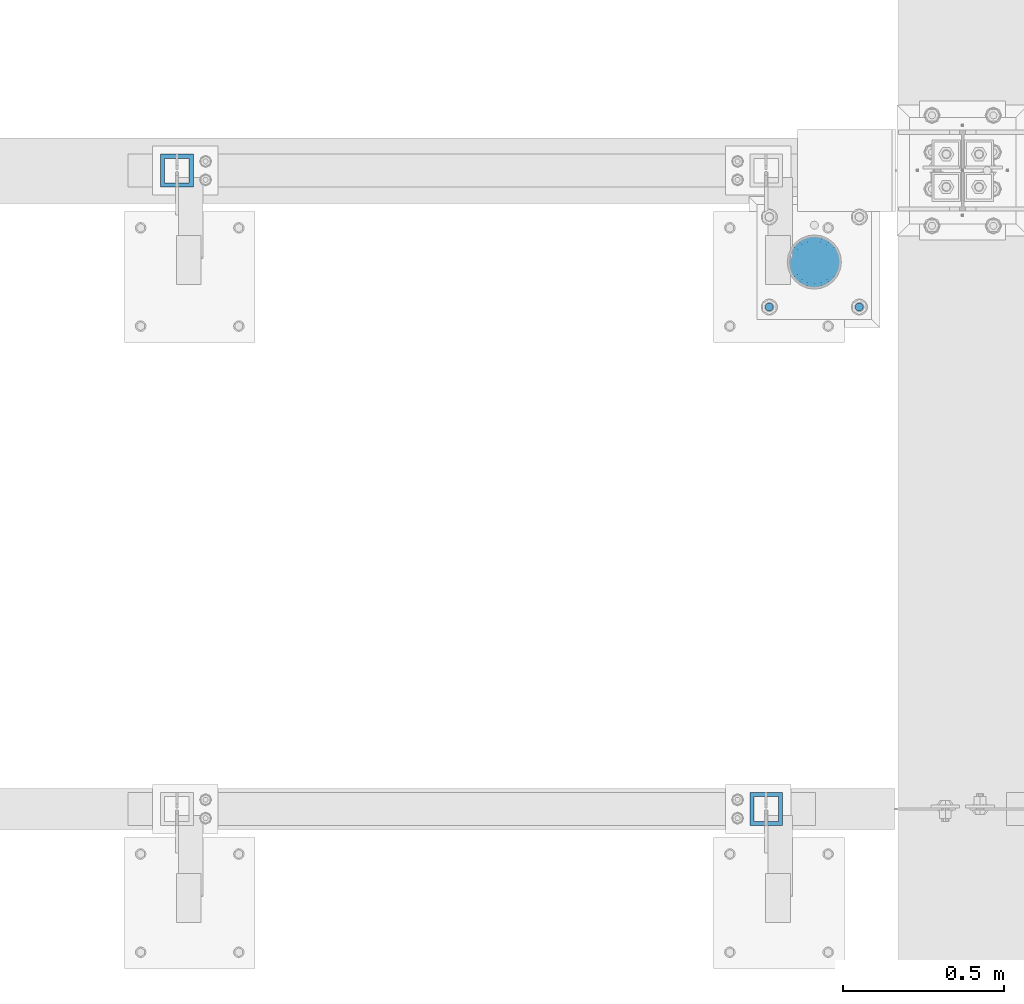
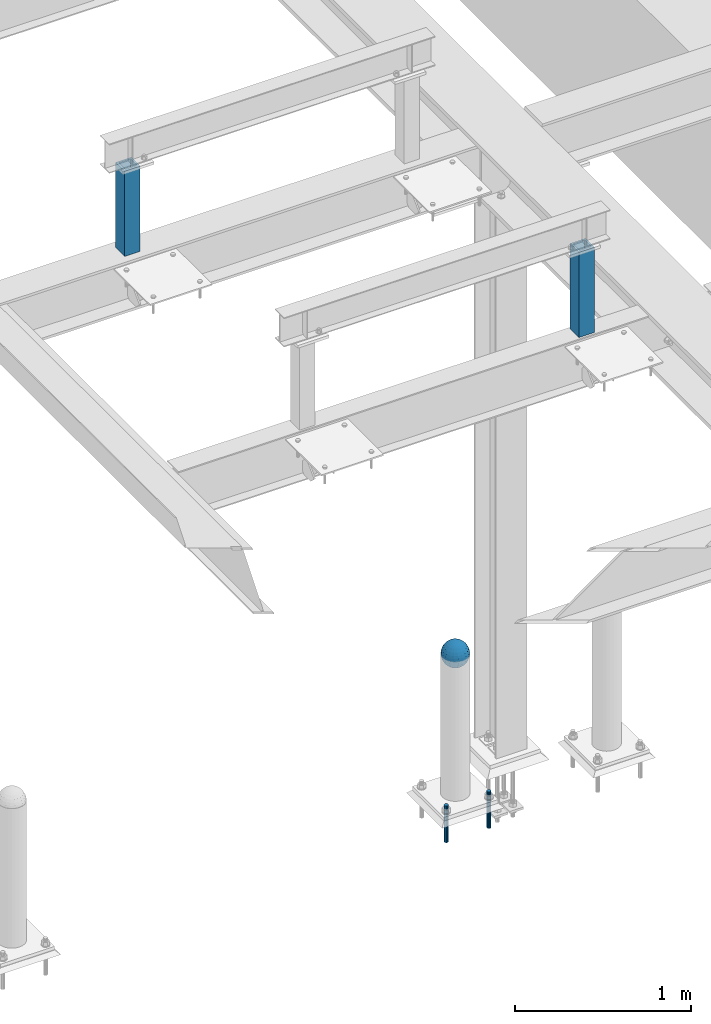
# One storey, part 1443 of 3843: 5 columns, 4 elements without a shape of their own.
"""IFC2X3 building model written with IfcOpenShell, lengths in millimetres."""

from ifc_helpers import new_model, si_unit, frame, origin_with_axes, place, context, subcontext, project, spatial, faceted_brep, material, type_object, element, aggregate, save


model = new_model("IFC2X3")

# Units and contexts
model_context = context("Model", 3, precision=1e-05, world=origin_with_axes())
body_context = subcontext(model_context, "Body", "Model", "MODEL_VIEW")
ifc_project = project(units=[si_unit("LENGTHUNIT", "METRE", prefix="MILLI"), si_unit("AREAUNIT", "SQUARE_METRE"), si_unit("VOLUMEUNIT", "CUBIC_METRE"), si_unit("MASSUNIT", "GRAM", prefix="KILO"), si_unit("TIMEUNIT", "SECOND"), si_unit("PLANEANGLEUNIT", "RADIAN"), si_unit("SOLIDANGLEUNIT", "STERADIAN"), si_unit("THERMODYNAMICTEMPERATUREUNIT", "DEGREE_CELSIUS"), si_unit("LUMINOUSINTENSITYUNIT", "LUMEN")], contexts=[model_context])

# Site, building, storey
site_placement = place(None, origin_with_axes())
site = spatial("IfcSite", under=ifc_project, at=site_placement, CompositionType="ELEMENT")
building_placement = place(site_placement, origin_with_axes())
building = spatial("IfcBuilding", under=site, at=building_placement, Name="Undefined", CompositionType="ELEMENT")
storey_placement = place(building_placement, origin_with_axes())
storey = spatial("IfcBuildingStorey", under=building, at=storey_placement, Name="Undefined", CompositionType="ELEMENT", Elevation=0.0)

# Assembly, column
assembly_1_placement = place(storey_placement, origin_with_axes())
assembly_1 = element("IfcElementAssembly", 1, at=assembly_1_placement, inside=storey, Name="CONC. FILL", AssemblyPlace="NOTDEFINED", PredefinedType="REINFORCEMENT_UNIT")
ifc_material_1 = material(Name="CONCRETE/1500")
column_type_1 = type_object("IfcColumnType", PredefinedType="NOTDEFINED")
column_1_placement = place(assembly_1_placement, frame((36115.6715698242, 14714.9457781578, 31411.8625), z_axis=(-1.0, 0.0, 0.0), x_axis=(0.0, 0.0, 1.0)))
column_1 = element("IfcColumn", 2, at=column_1_placement, type_object=column_type_1, material=ifc_material_1, Name="CONC. FILL", context=body_context, shape_type="Brep", body=[
    faceted_brep([(0.0, 0.0, 2.0), (0.0, -0.619999999995343, 1.89999999999964), (3.36549999999988, -7.1422259999963, 21.9814139999999), (3.36549999999988, 0.0, 23.1139999999996), (0.0, -1.17999999999302, 1.6200000000008), (3.36549999999988, -13.5910319999966, 18.6992260000006), (0.0, -1.61999999999534, 1.18000000000029), (3.36549999999988, -18.699225999997, 13.5910320000003), (0.0, -1.89999999999418, 0.6200000000008), (3.36549999999988, -21.9814139999944, 7.14222599999994), (0.0, -2.0, 0.0), (3.36549999999988, -23.1140000000014, 0.0), (0.0, -1.89999999999418, -0.6200000000008), (3.36549999999988, -21.9814139999944, -7.14222599999994), (0.0, -1.61999999999534, -1.18000000000029), (3.36549999999988, -18.699225999997, -13.5910320000003), (0.0, -1.17999999999302, -1.6200000000008), (3.36549999999988, -13.5910319999966, -18.6992260000006), (0.0, -0.619999999995343, -1.89999999999964), (3.36549999999988, -7.1422259999963, -21.9814139999999), (0.0, 0.0, -2.0), (3.36549999999988, 0.0, -23.1139999999996), (0.0, 0.619999999995343, -1.89999999999964), (3.36549999999988, 7.1422259999963, -21.9814139999999), (0.0, 1.17999999999302, -1.6200000000008), (3.36549999999988, 13.5910319999966, -18.6992260000006), (0.0, 1.61999999999534, -1.18000000000029), (3.36549999999988, 18.699225999997, -13.5910320000003), (0.0, 1.89999999999418, -0.6200000000008), (3.36549999999988, 21.9814139999944, -7.14222599999994), (0.0, 2.0, 0.0), (3.36549999999988, 23.1140000000014, 0.0), (0.0, 1.89999999999418, 0.6200000000008), (3.36549999999988, 21.9814139999944, 7.14222599999994), (0.0, 1.61999999999534, 1.18000000000029), (3.36549999999988, 18.699225999997, 13.5910320000003), (0.0, 1.17999999999302, 1.6200000000008), (3.36549999999988, 13.5910319999966, 18.6992260000006), (0.0, 0.619999999995343, 1.89999999999964), (3.36549999999988, 7.1422259999963, 21.9814139999999), (8.41374999999971, -11.1214661999984, 34.2282018000005), (8.41374999999971, 0.0, 35.9917999999998), (8.41374999999971, -21.1631784000056, 29.1173662000001), (8.41374999999971, -29.1173661999928, 21.1631784000001), (8.41374999999971, -34.2282017999969, 11.1214662000002), (8.41374999999971, -35.9918000000034, 0.0), (8.41374999999971, -34.2282017999969, -11.1214662000002), (8.41374999999971, -29.1173661999928, -21.1631784000001), (8.41374999999971, -21.1631784000056, -29.1173662000001), (8.41374999999971, -11.1214661999984, -34.2282018000005), (8.41374999999971, 0.0, -35.9917999999998), (8.41374999999971, 11.1214661999984, -34.2282018000005), (8.41374999999971, 21.1631784000056, -29.1173662000001), (8.41374999999971, 29.1173661999928, -21.1631784000001), (8.41374999999971, 34.2282017999969, -11.1214662000002), (8.41374999999971, 35.9918000000034, 0.0), (8.41374999999971, 34.2282017999969, 11.1214662000002), (8.41374999999971, 29.1173661999928, 21.1631784000001), (8.41374999999971, 21.1631784000056, 29.1173662000001), (8.41374999999971, 11.1214661999984, 34.2282018000005), (16.8274999999994, -15.3047700000025, 47.1030300000002), (16.8274999999994, 0.0, 49.5300000000007), (16.8274999999994, -29.1236400000053, 40.0697700000001), (16.8274999999994, -40.0697700000019, 29.1236399999998), (16.8274999999994, -47.1030299999984, 15.3047700000006), (16.8274999999994, -49.5299999999988, 0.0), (16.8274999999994, -47.1030299999984, -15.3047700000006), (16.8274999999994, -40.0697700000019, -29.1236399999998), (16.8274999999994, -29.1236400000053, -40.0697700000001), (16.8274999999994, -15.3047700000025, -47.1030300000002), (16.8274999999994, 0.0, -49.5300000000007), (16.8274999999994, 15.3047700000025, -47.1030300000002), (16.8274999999994, 29.1236400000053, -40.0697700000001), (16.8274999999994, 40.0697700000019, -29.1236399999998), (16.8274999999994, 47.1030299999984, -15.3047700000006), (16.8274999999994, 49.5299999999988, 0.0), (16.8274999999994, 47.1030299999984, 15.3047700000006), (16.8274999999994, 40.0697700000019, 29.1236399999998), (16.8274999999994, 29.1236400000053, 40.0697700000001), (16.8274999999994, 15.3047700000025, 47.1030300000002), (33.6549999999988, -20.4063599999936, 62.8040400000009), (33.6549999999988, 0.0, 66.0400000000009), (33.6549999999988, -38.831520000007, 53.4263599999995), (33.6549999999988, -53.4263599999977, 38.8315199999997), (33.6549999999988, -62.8040400000027, 20.4063600000009), (33.6549999999988, -66.0399999999936, 0.0), (33.6549999999988, -62.8040400000027, -20.4063600000009), (33.6549999999988, -53.4263599999977, -38.8315199999997), (33.6549999999988, -38.831520000007, -53.4263599999995), (33.6549999999988, -20.4063599999936, -62.8040400000009), (33.6549999999988, 0.0, -66.0400000000009), (33.6549999999988, 20.4063599999936, -62.8040400000009), (33.6549999999988, 38.831520000007, -53.4263599999995), (33.6549999999988, 53.4263599999977, -38.8315199999997), (33.6549999999988, 62.8040400000027, -20.4063600000009), (33.6549999999988, 66.0399999999936, 0.0), (33.6549999999988, 62.8040400000027, 20.4063600000009), (33.6549999999988, 53.4263599999977, 38.8315199999997), (33.6549999999988, 38.831520000007, 53.4263599999995), (33.6549999999988, 20.4063599999936, 62.8040400000009), (50.4824999999983, -23.3907901500061, 71.9891308499991), (50.4824999999983, 0.0, 75.6983500000006), (50.4824999999983, -44.5106298000028, 61.23996515), (50.4824999999983, -61.2399651500018, 44.5106297999992), (50.4824999999983, -71.9891308499937, 23.3907901500006), (50.4824999999983, -75.698350000006, 0.0), (50.4824999999983, -71.9891308499937, -23.3907901500006), (50.4824999999983, -61.2399651500018, -44.5106297999992), (50.4824999999983, -44.5106298000028, -61.23996515), (50.4824999999983, -23.3907901500061, -71.9891308499991), (50.4824999999983, 0.0, -75.6983500000006), (50.4824999999983, 23.3907901500061, -71.9891308499991), (50.4824999999983, 44.5106298000028, -61.23996515), (50.4824999999983, 61.2399651500018, -44.5106297999992), (50.4824999999983, 71.9891308499937, -23.3907901500006), (50.4824999999983, 75.698350000006, 0.0), (50.4824999999983, 71.9891308499937, 23.3907901500006), (50.4824999999983, 61.2399651500018, 44.5106297999992), (50.4824999999983, 44.5106298000028, 61.23996515), (50.4824999999983, 23.3907901500061, 71.9891308499991), (67.3099999999977, -24.9977910000016, 76.9349490000004), (67.3099999999977, 0.0, 80.8989999999994), (67.3099999999977, -47.5686120000028, 65.4472910000004), (67.3099999999977, -65.447291000004, 47.5686119999991), (67.3099999999977, -76.9349490000022, 24.9977909999998), (67.3099999999977, -80.8990000000049, 0.0), (67.3099999999977, -76.9349490000022, -24.9977909999998), (67.3099999999977, -65.447291000004, -47.5686119999991), (67.3099999999977, -47.5686120000028, -65.4472910000004), (67.3099999999977, -24.9977910000016, -76.9349490000004), (67.3099999999977, 0.0, -80.8989999999994), (67.3099999999977, 24.9977910000016, -76.9349490000004), (67.3099999999977, 47.5686120000028, -65.4472910000004), (67.3099999999977, 65.447291000004, -47.5686119999991), (67.3099999999977, 76.9349490000022, -24.9977909999998), (67.3099999999977, 80.8990000000049, 0.0), (67.3099999999977, 76.9349490000022, 24.9977909999998), (67.3099999999977, 65.447291000004, 47.5686119999991), (67.3099999999977, 47.5686120000028, 65.4472910000004), (67.3099999999977, 24.9977910000016, 76.9349490000004), (84.1374999999935, -25.5079499999993, 78.5050499999998), (84.1374999999935, 0.0, 82.5499999999993), (84.1374999999935, -48.5393999999942, 66.7829500000007), (84.1374999999935, -66.7829499999934, 48.5393999999997), (84.1374999999935, -78.505050000007, 25.5079499999993), (84.1374999999935, -82.5500000000029, 0.0), (84.1374999999935, -78.505050000007, -25.5079499999993), (84.1374999999935, -66.7829499999934, -48.5393999999997), (84.1374999999935, -48.5393999999942, -66.7829500000007), (84.1374999999935, -25.5079499999993, -78.5050499999998), (84.1374999999935, 0.0, -82.5499999999993), (84.1374999999935, 25.5079499999993, -78.5050499999998), (84.1374999999935, 48.5393999999942, -66.7829500000007), (84.1374999999935, 66.7829499999934, -48.5393999999997), (84.1374999999935, 78.505050000007, -25.5079499999993), (84.1374999999935, 82.5500000000029, 0.0), (84.1374999999935, 78.505050000007, 25.5079499999993), (84.1374999999935, 66.7829499999934, 48.5393999999997), (84.1374999999935, 48.5393999999942, 66.7829500000007), (84.1374999999935, 25.5079499999993, 78.5050499999998), (100.964999999993, -24.9977910000016, 76.9349490000004), (100.964999999993, 0.0, 80.8989999999994), (100.964999999993, -47.5686120000028, 65.4472910000004), (100.964999999993, -65.447291000004, 47.5686119999991), (100.964999999993, -76.9349490000022, 24.9977909999998), (100.964999999993, -80.8990000000049, 0.0), (100.964999999993, -76.9349490000022, -24.9977909999998), (100.964999999993, -65.447291000004, -47.5686119999991), (100.964999999993, -47.5686120000028, -65.4472910000004), (100.964999999993, -24.9977910000016, -76.9349490000004), (100.964999999993, 0.0, -80.8989999999994), (100.964999999993, 24.9977910000016, -76.9349490000004), (100.964999999993, 47.5686120000028, -65.4472910000004), (100.964999999993, 65.447291000004, -47.5686119999991), (100.964999999993, 76.9349490000022, -24.9977909999998), (100.964999999993, 80.8990000000049, 0.0), (100.964999999993, 76.9349490000022, 24.9977909999998), (100.964999999993, 65.447291000004, 47.5686119999991), (100.964999999993, 47.5686120000028, 65.4472910000004), (100.964999999993, 24.9977910000016, 76.9349490000004), (117.792499999992, -23.3907901500061, 71.9891308499991), (117.792499999992, 0.0, 75.6983500000006), (117.792499999992, -44.5106298000028, 61.23996515), (117.792499999992, -61.2399651500018, 44.5106297999992), (117.792499999992, -71.9891308499937, 23.3907901500006), (117.792499999992, -75.698350000006, 0.0), (117.792499999992, -71.9891308499937, -23.3907901500006), (117.792499999992, -61.2399651500018, -44.5106297999992), (117.792499999992, -44.5106298000028, -61.23996515), (117.792499999992, -23.3907901500061, -71.9891308499991), (117.792499999992, 0.0, -75.6983500000006), (117.792499999992, 23.3907901500061, -71.9891308499991), (117.792499999992, 44.5106298000028, -61.23996515), (117.792499999992, 61.2399651500018, -44.5106297999992), (117.792499999992, 71.9891308499937, -23.3907901500006), (117.792499999992, 75.698350000006, 0.0), (117.792499999992, 71.9891308499937, 23.3907901500006), (117.792499999992, 61.2399651500018, 44.5106297999992), (117.792499999992, 44.5106298000028, 61.23996515), (117.792499999992, 23.3907901500061, 71.9891308499991), (134.619999999992, -20.4063599999936, 62.8040400000009), (134.619999999992, 0.0, 66.0400000000009), (134.619999999992, -38.831520000007, 53.4263599999995), (134.619999999992, -53.4263599999977, 38.8315199999997), (134.619999999992, -62.8040400000027, 20.4063600000009), (134.619999999992, -66.0399999999936, 0.0), (134.619999999992, -62.8040400000027, -20.4063600000009), (134.619999999992, -53.4263599999977, -38.8315199999997), (134.619999999992, -38.831520000007, -53.4263599999995), (134.619999999992, -20.4063599999936, -62.8040400000009), (134.619999999992, 0.0, -66.0400000000009), (134.619999999992, 20.4063599999936, -62.8040400000009), (134.619999999992, 38.831520000007, -53.4263599999995), (134.619999999992, 53.4263599999977, -38.8315199999997), (134.619999999992, 62.8040400000027, -20.4063600000009), (134.619999999992, 66.0399999999936, 0.0), (134.619999999992, 62.8040400000027, 20.4063600000009), (134.619999999992, 53.4263599999977, 38.8315199999997), (134.619999999992, 38.831520000007, 53.4263599999995), (134.619999999992, 20.4063599999936, 62.8040400000009), (151.447499999991, -15.3047700000025, 47.1030300000002), (151.447499999991, 0.0, 49.5300000000007), (151.447499999991, -29.1236400000053, 40.0697700000001), (151.447499999991, -40.0697700000019, 29.1236399999998), (151.447499999991, -47.1030299999984, 15.3047700000006), (151.447499999991, -49.5299999999988, 0.0), (151.447499999991, -47.1030299999984, -15.3047700000006), (151.447499999991, -40.0697700000019, -29.1236399999998), (151.447499999991, -29.1236400000053, -40.0697700000001), (151.447499999991, -15.3047700000025, -47.1030300000002), (151.447499999991, 0.0, -49.5300000000007), (151.447499999991, 15.3047700000025, -47.1030300000002), (151.447499999991, 29.1236400000053, -40.0697700000001), (151.447499999991, 40.0697700000019, -29.1236399999998), (151.447499999991, 47.1030299999984, -15.3047700000006), (151.447499999991, 49.5299999999988, 0.0), (151.447499999991, 47.1030299999984, 15.3047700000006), (151.447499999991, 40.0697700000019, 29.1236399999998), (151.447499999991, 29.1236400000053, 40.0697700000001), (151.447499999991, 15.3047700000025, 47.1030300000002), (159.861249999991, -11.1214661999984, 34.2282018000005), (159.861249999991, 0.0, 35.9917999999998), (159.861249999991, -21.1631784000056, 29.1173662000001), (159.861249999991, -29.1173661999928, 21.1631784000001), (159.861249999991, -34.2282017999969, 11.1214662000002), (159.861249999991, -35.9918000000034, 0.0), (159.861249999991, -34.2282017999969, -11.1214662000002), (159.861249999991, -29.1173661999928, -21.1631784000001), (159.861249999991, -21.1631784000056, -29.1173662000001), (159.861249999991, -11.1214661999984, -34.2282018000005), (159.861249999991, 0.0, -35.9917999999998), (159.861249999991, 11.1214661999984, -34.2282018000005), (159.861249999991, 21.1631784000056, -29.1173662000001), (159.861249999991, 29.1173661999928, -21.1631784000001), (159.861249999991, 34.2282017999969, -11.1214662000002), (159.861249999991, 35.9918000000034, 0.0), (159.861249999991, 34.2282017999969, 11.1214662000002), (159.861249999991, 29.1173661999928, 21.1631784000001), (159.861249999991, 21.1631784000056, 29.1173662000001), (159.861249999991, 11.1214661999984, 34.2282018000005), (164.909499999991, -7.1422259999963, 21.9814139999999), (164.909499999991, 0.0, 23.1139999999996), (164.909499999991, -13.5910319999966, 18.6992260000006), (164.909499999991, -18.699225999997, 13.5910320000003), (164.909499999991, -21.9814139999944, 7.14222599999994), (164.909499999991, -23.1140000000014, 0.0), (164.909499999991, -21.9814139999944, -7.14222599999994), (164.909499999991, -18.699225999997, -13.5910320000003), (164.909499999991, -13.5910319999966, -18.6992260000006), (164.909499999991, -7.1422259999963, -21.9814139999999), (164.909499999991, 0.0, -23.1139999999996), (164.909499999991, 7.1422259999963, -21.9814139999999), (164.909499999991, 13.5910319999966, -18.6992260000006), (164.909499999991, 18.699225999997, -13.5910320000003), (164.909499999991, 21.9814139999944, -7.14222599999994), (164.909499999991, 23.1140000000014, 0.0), (164.909499999991, 21.9814139999944, 7.14222599999994), (164.909499999991, 18.699225999997, 13.5910320000003), (164.909499999991, 13.5910319999966, 18.6992260000006), (164.909499999991, 7.1422259999963, 21.9814139999999), (168.274999999991, -0.619999999995343, 1.89999999999964), (168.274999999991, 0.0, 2.0), (168.274999999991, -1.17999999999302, 1.6200000000008), (168.274999999991, -1.61999999999534, 1.18000000000029), (168.274999999991, -1.89999999999418, 0.6200000000008), (168.274999999991, -2.0, 0.0), (168.274999999991, -1.89999999999418, -0.6200000000008), (168.274999999991, -1.61999999999534, -1.18000000000029), (168.274999999991, -1.17999999999302, -1.6200000000008), (168.274999999991, -0.619999999995343, -1.89999999999964), (168.274999999991, 0.0, -2.0), (168.274999999991, 0.619999999995343, -1.89999999999964), (168.274999999991, 1.17999999999302, -1.6200000000008), (168.274999999991, 1.61999999999534, -1.18000000000029), (168.274999999991, 1.89999999999418, -0.6200000000008), (168.274999999991, 2.0, 0.0), (168.274999999991, 1.89999999999418, 0.6200000000008), (168.274999999991, 1.61999999999534, 1.18000000000029), (168.274999999991, 1.17999999999302, 1.6200000000008), (168.274999999991, 0.619999999995343, 1.89999999999964)], [[[0, 1, 2, 3]], [[1, 4, 5, 2]], [[4, 6, 7, 5]], [[6, 8, 9, 7]], [[8, 10, 11, 9]], [[10, 12, 13, 11]], [[12, 14, 15, 13]], [[14, 16, 17, 15]], [[16, 18, 19, 17]], [[18, 20, 21, 19]], [[20, 22, 23, 21]], [[22, 24, 25, 23]], [[24, 26, 27, 25]], [[26, 28, 29, 27]], [[28, 30, 31, 29]], [[30, 32, 33, 31]], [[32, 34, 35, 33]], [[34, 36, 37, 35]], [[36, 38, 39, 37]], [[38, 0, 3, 39]], [[38, 36, 34, 32, 30, 28, 26, 24, 22, 20, 18, 16, 14, 12, 10, 8, 6, 4, 1, 0]], [[3, 2, 40, 41]], [[2, 5, 42, 40]], [[5, 7, 43, 42]], [[7, 9, 44, 43]], [[9, 11, 45, 44]], [[11, 13, 46, 45]], [[13, 15, 47, 46]], [[15, 17, 48, 47]], [[17, 19, 49, 48]], [[19, 21, 50, 49]], [[21, 23, 51, 50]], [[23, 25, 52, 51]], [[25, 27, 53, 52]], [[27, 29, 54, 53]], [[29, 31, 55, 54]], [[31, 33, 56, 55]], [[33, 35, 57, 56]], [[35, 37, 58, 57]], [[37, 39, 59, 58]], [[39, 3, 41, 59]], [[41, 40, 60, 61]], [[40, 42, 62, 60]], [[42, 43, 63, 62]], [[43, 44, 64, 63]], [[44, 45, 65, 64]], [[45, 46, 66, 65]], [[46, 47, 67, 66]], [[47, 48, 68, 67]], [[48, 49, 69, 68]], [[49, 50, 70, 69]], [[50, 51, 71, 70]], [[51, 52, 72, 71]], [[52, 53, 73, 72]], [[53, 54, 74, 73]], [[54, 55, 75, 74]], [[55, 56, 76, 75]], [[56, 57, 77, 76]], [[57, 58, 78, 77]], [[58, 59, 79, 78]], [[59, 41, 61, 79]], [[61, 60, 80, 81]], [[60, 62, 82, 80]], [[62, 63, 83, 82]], [[63, 64, 84, 83]], [[64, 65, 85, 84]], [[65, 66, 86, 85]], [[66, 67, 87, 86]], [[67, 68, 88, 87]], [[68, 69, 89, 88]], [[69, 70, 90, 89]], [[70, 71, 91, 90]], [[71, 72, 92, 91]], [[72, 73, 93, 92]], [[73, 74, 94, 93]], [[74, 75, 95, 94]], [[75, 76, 96, 95]], [[76, 77, 97, 96]], [[77, 78, 98, 97]], [[78, 79, 99, 98]], [[79, 61, 81, 99]], [[81, 80, 100, 101]], [[80, 82, 102, 100]], [[82, 83, 103, 102]], [[83, 84, 104, 103]], [[84, 85, 105, 104]], [[85, 86, 106, 105]], [[86, 87, 107, 106]], [[87, 88, 108, 107]], [[88, 89, 109, 108]], [[89, 90, 110, 109]], [[90, 91, 111, 110]], [[91, 92, 112, 111]], [[92, 93, 113, 112]], [[93, 94, 114, 113]], [[94, 95, 115, 114]], [[95, 96, 116, 115]], [[96, 97, 117, 116]], [[97, 98, 118, 117]], [[98, 99, 119, 118]], [[99, 81, 101, 119]], [[101, 100, 120, 121]], [[100, 102, 122, 120]], [[102, 103, 123, 122]], [[103, 104, 124, 123]], [[104, 105, 125, 124]], [[105, 106, 126, 125]], [[106, 107, 127, 126]], [[107, 108, 128, 127]], [[108, 109, 129, 128]], [[109, 110, 130, 129]], [[110, 111, 131, 130]], [[111, 112, 132, 131]], [[112, 113, 133, 132]], [[113, 114, 134, 133]], [[114, 115, 135, 134]], [[115, 116, 136, 135]], [[116, 117, 137, 136]], [[117, 118, 138, 137]], [[118, 119, 139, 138]], [[119, 101, 121, 139]], [[121, 120, 140, 141]], [[120, 122, 142, 140]], [[122, 123, 143, 142]], [[123, 124, 144, 143]], [[124, 125, 145, 144]], [[125, 126, 146, 145]], [[126, 127, 147, 146]], [[127, 128, 148, 147]], [[128, 129, 149, 148]], [[129, 130, 150, 149]], [[130, 131, 151, 150]], [[131, 132, 152, 151]], [[132, 133, 153, 152]], [[133, 134, 154, 153]], [[134, 135, 155, 154]], [[135, 136, 156, 155]], [[136, 137, 157, 156]], [[137, 138, 158, 157]], [[138, 139, 159, 158]], [[139, 121, 141, 159]], [[141, 140, 160, 161]], [[140, 142, 162, 160]], [[142, 143, 163, 162]], [[143, 144, 164, 163]], [[144, 145, 165, 164]], [[145, 146, 166, 165]], [[146, 147, 167, 166]], [[147, 148, 168, 167]], [[148, 149, 169, 168]], [[149, 150, 170, 169]], [[150, 151, 171, 170]], [[151, 152, 172, 171]], [[152, 153, 173, 172]], [[153, 154, 174, 173]], [[154, 155, 175, 174]], [[155, 156, 176, 175]], [[156, 157, 177, 176]], [[157, 158, 178, 177]], [[158, 159, 179, 178]], [[159, 141, 161, 179]], [[161, 160, 180, 181]], [[160, 162, 182, 180]], [[162, 163, 183, 182]], [[163, 164, 184, 183]], [[164, 165, 185, 184]], [[165, 166, 186, 185]], [[166, 167, 187, 186]], [[167, 168, 188, 187]], [[168, 169, 189, 188]], [[169, 170, 190, 189]], [[170, 171, 191, 190]], [[171, 172, 192, 191]], [[172, 173, 193, 192]], [[173, 174, 194, 193]], [[174, 175, 195, 194]], [[175, 176, 196, 195]], [[176, 177, 197, 196]], [[177, 178, 198, 197]], [[178, 179, 199, 198]], [[179, 161, 181, 199]], [[181, 180, 200, 201]], [[180, 182, 202, 200]], [[182, 183, 203, 202]], [[183, 184, 204, 203]], [[184, 185, 205, 204]], [[185, 186, 206, 205]], [[186, 187, 207, 206]], [[187, 188, 208, 207]], [[188, 189, 209, 208]], [[189, 190, 210, 209]], [[190, 191, 211, 210]], [[191, 192, 212, 211]], [[192, 193, 213, 212]], [[193, 194, 214, 213]], [[194, 195, 215, 214]], [[195, 196, 216, 215]], [[196, 197, 217, 216]], [[197, 198, 218, 217]], [[198, 199, 219, 218]], [[199, 181, 201, 219]], [[201, 200, 220, 221]], [[200, 202, 222, 220]], [[202, 203, 223, 222]], [[203, 204, 224, 223]], [[204, 205, 225, 224]], [[205, 206, 226, 225]], [[206, 207, 227, 226]], [[207, 208, 228, 227]], [[208, 209, 229, 228]], [[209, 210, 230, 229]], [[210, 211, 231, 230]], [[211, 212, 232, 231]], [[212, 213, 233, 232]], [[213, 214, 234, 233]], [[214, 215, 235, 234]], [[215, 216, 236, 235]], [[216, 217, 237, 236]], [[217, 218, 238, 237]], [[218, 219, 239, 238]], [[219, 201, 221, 239]], [[221, 220, 240, 241]], [[220, 222, 242, 240]], [[222, 223, 243, 242]], [[223, 224, 244, 243]], [[224, 225, 245, 244]], [[225, 226, 246, 245]], [[226, 227, 247, 246]], [[227, 228, 248, 247]], [[228, 229, 249, 248]], [[229, 230, 250, 249]], [[230, 231, 251, 250]], [[231, 232, 252, 251]], [[232, 233, 253, 252]], [[233, 234, 254, 253]], [[234, 235, 255, 254]], [[235, 236, 256, 255]], [[236, 237, 257, 256]], [[237, 238, 258, 257]], [[238, 239, 259, 258]], [[239, 221, 241, 259]], [[241, 240, 260, 261]], [[240, 242, 262, 260]], [[242, 243, 263, 262]], [[243, 244, 264, 263]], [[244, 245, 265, 264]], [[245, 246, 266, 265]], [[246, 247, 267, 266]], [[247, 248, 268, 267]], [[248, 249, 269, 268]], [[249, 250, 270, 269]], [[250, 251, 271, 270]], [[251, 252, 272, 271]], [[252, 253, 273, 272]], [[253, 254, 274, 273]], [[254, 255, 275, 274]], [[255, 256, 276, 275]], [[256, 257, 277, 276]], [[257, 258, 278, 277]], [[258, 259, 279, 278]], [[259, 241, 261, 279]], [[261, 260, 280, 281]], [[260, 262, 282, 280]], [[262, 263, 283, 282]], [[263, 264, 284, 283]], [[264, 265, 285, 284]], [[265, 266, 286, 285]], [[266, 267, 287, 286]], [[267, 268, 288, 287]], [[268, 269, 289, 288]], [[269, 270, 290, 289]], [[270, 271, 291, 290]], [[271, 272, 292, 291]], [[272, 273, 293, 292]], [[273, 274, 294, 293]], [[274, 275, 295, 294]], [[275, 276, 296, 295]], [[276, 277, 297, 296]], [[277, 278, 298, 297]], [[278, 279, 299, 298]], [[279, 261, 281, 299]], [[282, 283, 284, 285, 286, 287, 288, 289, 290, 291, 292, 293, 294, 295, 296, 297, 298, 299, 281, 280]]]),
])
aggregate(assembly_1, [column_1])

# Assembly, columns
assembly_2_placement = place(storey_placement, origin_with_axes())
assembly_2 = element("IfcElementAssembly", 3, at=assembly_2_placement, inside=storey, Name="TEMPLATE", AssemblyPlace="NOTDEFINED", PredefinedType="RIGID_FRAME")
ifc_material_2 = material(Name="STEEL/316 SS")
column_type_2 = type_object("IfcColumnType", PredefinedType="NOTDEFINED")
column_2_placement = place(assembly_2_placement, frame((36255.3715698242, 14575.2457781578, 30581.6), z_axis=(1.0, 0.0, 0.0), x_axis=(0.0, 0.0, -1.0)))
column_2 = element("IfcColumn", 4, at=column_2_placement, type_object=column_type_2, material=ifc_material_2, Name="ANCHOR_ROD", context=body_context, shape_type="Brep", body=[
    faceted_brep([(0.0, -12.6999999999971, 0.0), (0.0, -10.9985226280696, -6.34999999999854), (253.999, -10.9985226280696, -6.34999999999854), (253.999, -12.6999999999971, 0.0), (0.0, -6.35000000000582, -10.9985226280623), (253.999, -6.35000000000582, -10.9985226280623), (0.0, 0.0, -12.6999999999971), (253.999, 0.0, -12.6999999999971), (0.0, 6.35000000000582, -10.9985226280623), (253.999, 6.35000000000582, -10.9985226280623), (0.0, 10.9985226280696, -6.34999999999854), (253.999, 10.9985226280696, -6.34999999999854), (0.0, 12.6999999999971, 0.0), (253.999, 12.6999999999971, 0.0), (0.0, 10.9985226280696, 6.34999999999854), (253.999, 10.9985226280696, 6.34999999999854), (0.0, 6.35000000000582, 10.9985226280623), (253.999, 6.35000000000582, 10.9985226280623), (0.0, 0.0, 12.6999999999971), (253.999, 0.0, 12.6999999999971), (0.0, -6.35000000000582, 10.9985226280623), (253.999, -6.35000000000582, 10.9985226280623), (0.0, -10.9985226280696, 6.34999999999854), (253.999, -10.9985226280696, 6.34999999999854)], [[[0, 1, 2, 3]], [[1, 4, 5, 2]], [[4, 6, 7, 5]], [[6, 8, 9, 7]], [[8, 10, 11, 9]], [[10, 12, 13, 11]], [[12, 14, 15, 13]], [[14, 16, 17, 15]], [[16, 18, 19, 17]], [[18, 20, 21, 19]], [[20, 22, 23, 21]], [[22, 0, 3, 23]], [[5, 7, 9, 11, 13, 15, 17, 19, 21, 23, 3, 2]], [[22, 20, 18, 16, 14, 12, 10, 8, 6, 4, 1, 0]]]),
])
column_3_placement = place(assembly_2_placement, frame((35975.9715698242, 14575.2457781578, 30581.6), z_axis=(1.0, 0.0, 0.0), x_axis=(0.0, 0.0, -1.0)))
column_3 = element("IfcColumn", 5, at=column_3_placement, type_object=column_type_2, material=ifc_material_2, Name="ANCHOR_ROD", context=body_context, shape_type="Brep", body=[
    faceted_brep([(0.0, -12.6999999999971, 0.0), (0.0, -10.9985226280696, -6.34999999999854), (253.999, -10.9985226280696, -6.34999999999854), (253.999, -12.6999999999971, 0.0), (0.0, -6.35000000000582, -10.9985226280623), (253.999, -6.35000000000582, -10.9985226280623), (0.0, 0.0, -12.6999999999971), (253.999, 0.0, -12.6999999999971), (0.0, 6.35000000000582, -10.9985226280623), (253.999, 6.35000000000582, -10.9985226280623), (0.0, 10.9985226280696, -6.34999999999854), (253.999, 10.9985226280696, -6.34999999999854), (0.0, 12.6999999999971, 0.0), (253.999, 12.6999999999971, 0.0), (0.0, 10.9985226280696, 6.34999999999854), (253.999, 10.9985226280696, 6.34999999999854), (0.0, 6.35000000000582, 10.9985226280623), (253.999, 6.35000000000582, 10.9985226280623), (0.0, 0.0, 12.6999999999971), (253.999, 0.0, 12.6999999999971), (0.0, -6.35000000000582, 10.9985226280623), (253.999, -6.35000000000582, 10.9985226280623), (0.0, -10.9985226280696, 6.34999999999854), (253.999, -10.9985226280696, 6.34999999999854)], [[[0, 1, 2, 3]], [[1, 4, 5, 2]], [[4, 6, 7, 5]], [[6, 8, 9, 7]], [[8, 10, 11, 9]], [[10, 12, 13, 11]], [[12, 14, 15, 13]], [[14, 16, 17, 15]], [[16, 18, 19, 17]], [[18, 20, 21, 19]], [[20, 22, 23, 21]], [[22, 0, 3, 23]], [[5, 7, 9, 11, 13, 15, 17, 19, 21, 23, 3, 2]], [[22, 20, 18, 16, 14, 12, 10, 8, 6, 4, 1, 0]]]),
])
aggregate(assembly_2, [column_2, column_3])

# Assembly, column
assembly_3_placement = place(storey_placement, origin_with_axes())
assembly_3 = element("IfcElementAssembly", 6, at=assembly_3_placement, inside=storey, Name="POST", AssemblyPlace="NOTDEFINED", PredefinedType="RIGID_FRAME")
ifc_material_3 = material()
column_type_3 = type_object("IfcColumnType", Name="HSS4X4X1/2", PredefinedType="NOTDEFINED")
column_4_placement = place(assembly_3_placement, frame((35966.4, 13017.5, 34810.7), z_axis=(0.0, 1.0, 0.0), x_axis=(0.0, 0.0, 1.0)))
column_4 = element("IfcColumn", 7, at=column_4_placement, type_object=column_type_3, material=ifc_material_3, Name="POST", ObjectType="HSS4X4X1/2", context=body_context, shape_type="Brep", body=[
    faceted_brep([(0.0, 38.0999999999985, -38.0999999999985), (0.0, -38.0999999999985, -38.0999999999985), (590.549996948241, -38.0999999999985, -38.1000000000004), (590.549996948241, 38.0999999999985, -38.1000000000004), (0.0, -38.0999999999985, 38.1000000000004), (590.549996948241, -38.0999999999985, 38.1000000000004), (0.0, 38.0999999999985, 38.0999999999985), (590.549996948241, 38.0999999999985, 38.1000000000004), (0.0, 50.8000000000029, -50.8000000000029), (0.0, 50.8000000000029, 50.8000000000029), (590.549996948241, 50.8000000000029, 50.7999999999993), (590.549996948241, 50.8000000000029, -50.7999999999993), (0.0, -50.8000000000029, 50.8000000000029), (590.549996948241, -50.8000000000029, 50.7999999999993), (0.0, -50.8000000000029, -50.8000000000029), (590.549996948241, -50.8000000000029, -50.7999999999993)], [[[0, 1, 2, 3]], [[1, 4, 5, 2]], [[4, 6, 7, 5]], [[6, 0, 3, 7]], [[8, 9, 10, 11]], [[9, 12, 13, 10]], [[12, 14, 15, 13]], [[14, 8, 11, 15]], [[13, 15, 11, 10], [5, 7, 3, 2]], [[14, 12, 9, 8], [6, 4, 1, 0]]]),
])
aggregate(assembly_3, [column_4])

assembly_4_placement = place(storey_placement, origin_with_axes())
assembly_4 = element("IfcElementAssembly", 8, at=assembly_4_placement, inside=storey, Name="POST", AssemblyPlace="NOTDEFINED", PredefinedType="RIGID_FRAME")
column_5_placement = place(assembly_4_placement, frame((34137.6, 14998.7, 34810.7), z_axis=(0.0, 1.0, 0.0), x_axis=(0.0, 0.0, 1.0)))
column_5 = element("IfcColumn", 9, at=column_5_placement, type_object=column_type_3, material=ifc_material_3, Name="POST", ObjectType="HSS4X4X1/2", context=body_context, shape_type="Brep", body=[
    faceted_brep([(0.0, 38.0999999999985, -38.0999999999985), (0.0, -38.0999999999985, -38.0999999999985), (590.549996948241, -38.0999999999985, -38.1000000000004), (590.549996948241, 38.0999999999985, -38.1000000000004), (0.0, -38.0999999999985, 38.1000000000004), (590.549996948241, -38.0999999999985, 38.1000000000004), (0.0, 38.0999999999985, 38.0999999999985), (590.549996948241, 38.0999999999985, 38.1000000000004), (0.0, 50.8000000000029, -50.8000000000029), (0.0, 50.8000000000029, 50.8000000000029), (590.549996948241, 50.8000000000029, 50.7999999999993), (590.549996948241, 50.8000000000029, -50.7999999999993), (0.0, -50.8000000000029, 50.8000000000029), (590.549996948241, -50.8000000000029, 50.7999999999993), (0.0, -50.8000000000029, -50.8000000000029), (590.549996948241, -50.8000000000029, -50.7999999999993)], [[[0, 1, 2, 3]], [[1, 4, 5, 2]], [[4, 6, 7, 5]], [[6, 0, 3, 7]], [[8, 9, 10, 11]], [[9, 12, 13, 10]], [[12, 14, 15, 13]], [[14, 8, 11, 15]], [[13, 15, 11, 10], [5, 7, 3, 2]], [[14, 12, 9, 8], [6, 4, 1, 0]]]),
])
aggregate(assembly_4, [column_5])

save(model, "model.ifc")
